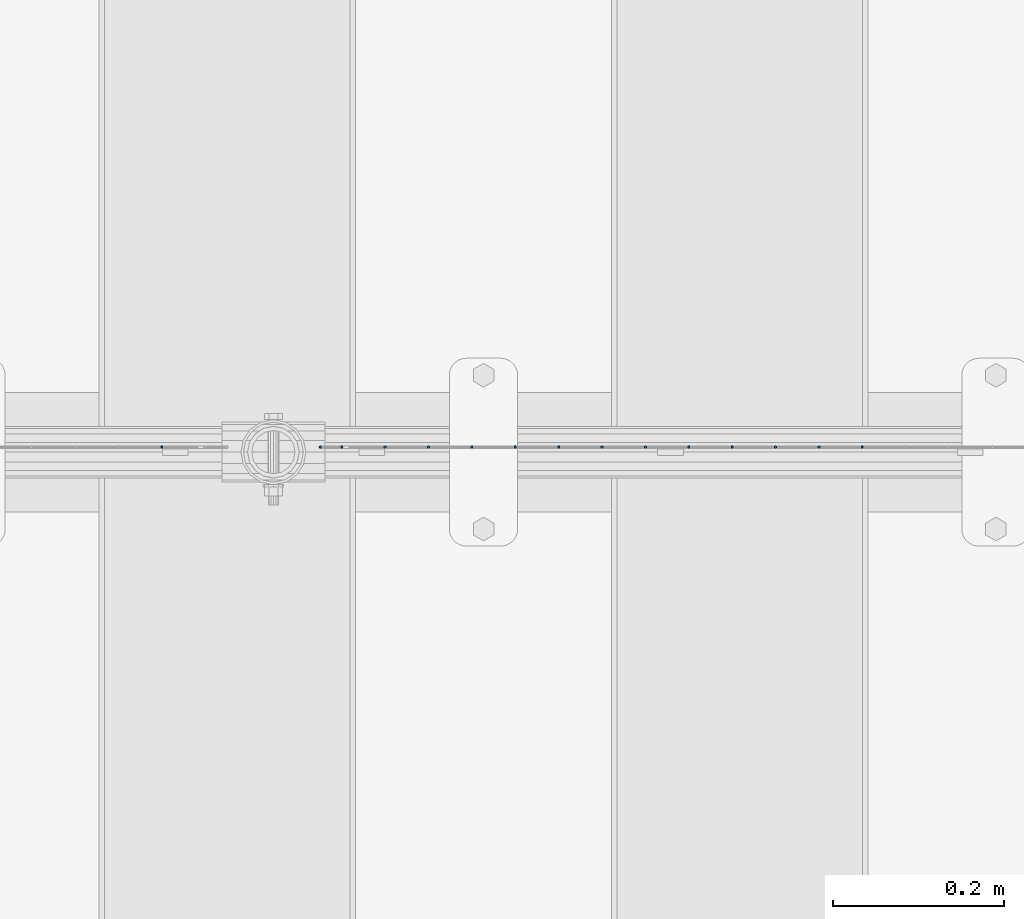
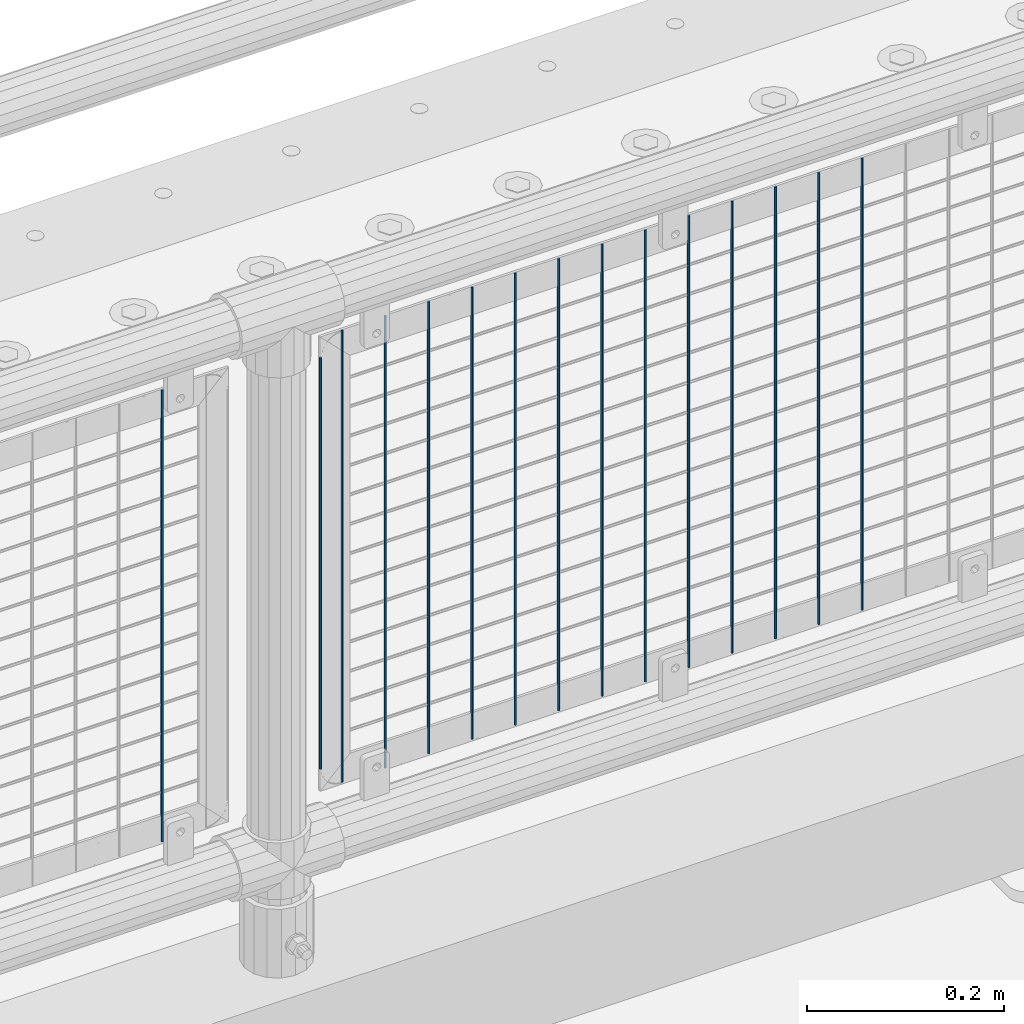
# One storey, part 65 of 242: 15 columns.
"""IFC2X3 building model written with IfcOpenShell, lengths in millimetres."""

from ifc_helpers import new_model, si_unit, frame, origin_with_axes, place, context, subcontext, project, spatial, faceted_brep, material, type_object, element, save


model = new_model("IFC2X3")

# Units and contexts
model_context = context("Model", 3, precision=1e-05, world=origin_with_axes())
body_context = subcontext(model_context, "Body", "Model", "MODEL_VIEW")
ifc_project = project(units=[si_unit("LENGTHUNIT", "METRE", prefix="MILLI"), si_unit("AREAUNIT", "SQUARE_METRE"), si_unit("VOLUMEUNIT", "CUBIC_METRE"), si_unit("MASSUNIT", "GRAM", prefix="KILO"), si_unit("TIMEUNIT", "SECOND"), si_unit("PLANEANGLEUNIT", "RADIAN"), si_unit("SOLIDANGLEUNIT", "STERADIAN"), si_unit("THERMODYNAMICTEMPERATUREUNIT", "DEGREE_CELSIUS"), si_unit("LUMINOUSINTENSITYUNIT", "LUMEN")], contexts=[model_context])

# Site, building, storey
site_placement = place(None, origin_with_axes())
site = spatial("IfcSite", under=ifc_project, at=site_placement, CompositionType="ELEMENT")
building_placement = place(site_placement, origin_with_axes())
building = spatial("IfcBuilding", under=site, at=building_placement, Name="Standard", CompositionType="ELEMENT")
storey_placement = place(building_placement, origin_with_axes())
storey = spatial("IfcBuildingStorey", under=building, at=storey_placement, Name="Undefined", CompositionType="ELEMENT", Elevation=0.0)

# Columns
ifc_material = material(Name="Misc_Undefined")
column_type = type_object("IfcColumnType", Name="D3", PredefinedType="NOTDEFINED")
for number, where, z_axis, x_axis in (
    (1, (-39506.484, -19329.5, 353.02), (-1.0, 0.0, 0.0), (0.0, 0.0, 1.0)),
    (2, (-39557.277, -19329.5, 353.02), (-1.0, 0.0, 0.0), (0.0, 0.0, 1.0)),
    (3, (-39608.07, -19329.5, 353.02), (-1.0, 0.0, 0.0), (0.0, 0.0, 1.0)),
    (4, (-39658.863, -19329.5, 353.02), (-1.0, 0.0, 0.0), (0.0, 0.0, 1.0)),
    (5, (-39709.656, -19329.5, 353.02), (-1.0, 0.0, 0.0), (0.0, 0.0, 1.0)),
    (6, (-39760.449, -19329.5, 353.02), (-1.0, 0.0, 0.0), (0.0, 0.0, 1.0)),
    (7, (-39811.242, -19329.5, 353.02), (-1.0, 0.0, 0.0), (0.0, 0.0, 1.0)),
    (8, (-39862.035, -19329.5, 353.02), (-1.0, 0.0, 0.0), (0.0, 0.0, 1.0)),
    (9, (-39912.828, -19329.5, 353.02), (-1.0, 0.0, 0.0), (0.0, 0.0, 1.0)),
    (10, (-39963.621, -19329.5, 353.02), (-1.0, 0.0, 0.0), (0.0, 0.0, 1.0)),
    (11, (-40014.414, -19329.5, 353.02), (-1.0, 0.0, 0.0), (0.0, 0.0, 1.0)),
    (12, (-40065.207, -19329.5, 353.02), (-1.0, 0.0, 0.0), (0.0, 0.0, 1.0)),
):
    element("IfcColumn", number, at=place(storey_placement, frame(where, z_axis=z_axis, x_axis=x_axis)), inside=storey, type_object=column_type, material=ifc_material, ObjectType="D3", context=body_context, shape_type="Brep", body=[
        faceted_brep([(0.0, -1.50000000000364, 0.0), (-3.63797880709171e-12, -0.750000000003638, -1.29903810567669), (560.0, -0.75, -1.29903810567703), (560.0, -1.5, 0.0), (0.0, 0.749999999996362, -1.29903810567669), (560.0, 0.75, -1.29903810567703), (-3.63797880709171e-12, 1.49999999999636, 0.0), (560.0, 1.5, 0.0), (0.0, 0.749999999996362, 1.29903810567669), (560.0, 0.75, 1.29903810567703), (-3.63797880709171e-12, -0.750000000003638, 1.29903810567669), (560.0, -0.75, 1.29903810567703)], [[[0, 1, 2, 3]], [[1, 4, 5, 2]], [[4, 6, 7, 5]], [[6, 8, 9, 7]], [[8, 10, 11, 9]], [[10, 0, 3, 11]], [[5, 7, 9, 11, 3, 2]], [[10, 8, 6, 4, 1, 0]]]),
    ])
column_placement = place(storey_placement, frame((-40141.0, -19329.5, 378.02), z_axis=(-1.0, 0.0, 0.0), x_axis=(0.0, 0.0, 1.0)))
element("IfcColumn", 13, at=column_placement, inside=storey, type_object=column_type, material=ifc_material, ObjectType="D3", context=body_context, shape_type="Brep", body=[
    faceted_brep([(0.0, -1.50000000000364, 0.0), (-3.63797880709171e-12, -0.750000000003638, -1.29903810567669), (510.0, -0.75, -1.29903810567703), (510.0, -1.5, 0.0), (0.0, 0.749999999996362, -1.29903810567669), (510.0, 0.75, -1.29903810567703), (-3.63797880709171e-12, 1.49999999999636, 0.0), (510.0, 1.5, 0.0), (0.0, 0.749999999996362, 1.29903810567669), (510.0, 0.75, 1.29903810567703), (-3.63797880709171e-12, -0.750000000003638, 1.29903810567669), (510.0, -0.75, 1.29903810567703)], [[[0, 1, 2, 3]], [[1, 4, 5, 2]], [[4, 6, 7, 5]], [[6, 8, 9, 7]], [[8, 10, 11, 9]], [[10, 0, 3, 11]], [[5, 7, 9, 11, 3, 2]], [[10, 8, 6, 4, 1, 0]]]),
])
for number, where, z_axis, x_axis in (
    (14, (-40116.0, -19329.5, 353.02), (-1.0, 0.0, 0.0), (0.0, 0.0, 1.0)),
    (15, (-40326.796, -19329.5, 353.02), (-1.0, 0.0, 0.0), (0.0, 0.0, 1.0)),
):
    element("IfcColumn", number, at=place(storey_placement, frame(where, z_axis=z_axis, x_axis=x_axis)), inside=storey, type_object=column_type, material=ifc_material, ObjectType="D3", context=body_context, shape_type="Brep", body=[
        faceted_brep([(0.0, -1.50000000000364, 0.0), (-3.63797880709171e-12, -0.750000000003638, -1.29903810567669), (560.0, -0.75, -1.29903810567703), (560.0, -1.5, 0.0), (0.0, 0.749999999996362, -1.29903810567669), (560.0, 0.75, -1.29903810567703), (-3.63797880709171e-12, 1.49999999999636, 0.0), (560.0, 1.5, 0.0), (0.0, 0.749999999996362, 1.29903810567669), (560.0, 0.75, 1.29903810567703), (-3.63797880709171e-12, -0.750000000003638, 1.29903810567669), (560.0, -0.75, 1.29903810567703)], [[[0, 1, 2, 3]], [[1, 4, 5, 2]], [[4, 6, 7, 5]], [[6, 8, 9, 7]], [[8, 10, 11, 9]], [[10, 0, 3, 11]], [[5, 7, 9, 11, 3, 2]], [[10, 8, 6, 4, 1, 0]]]),
    ])

save(model, "model.ifc")
